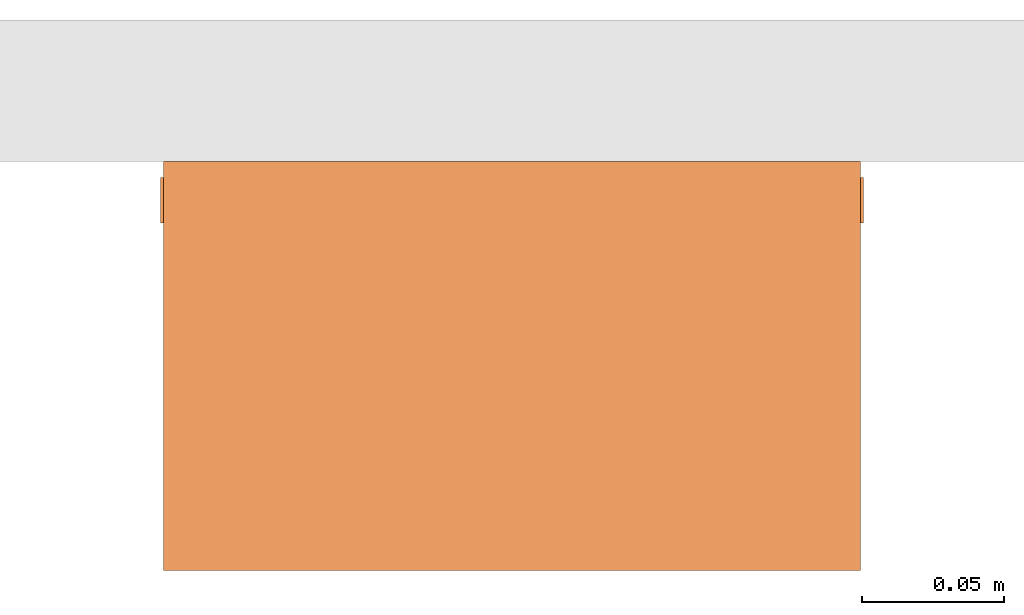
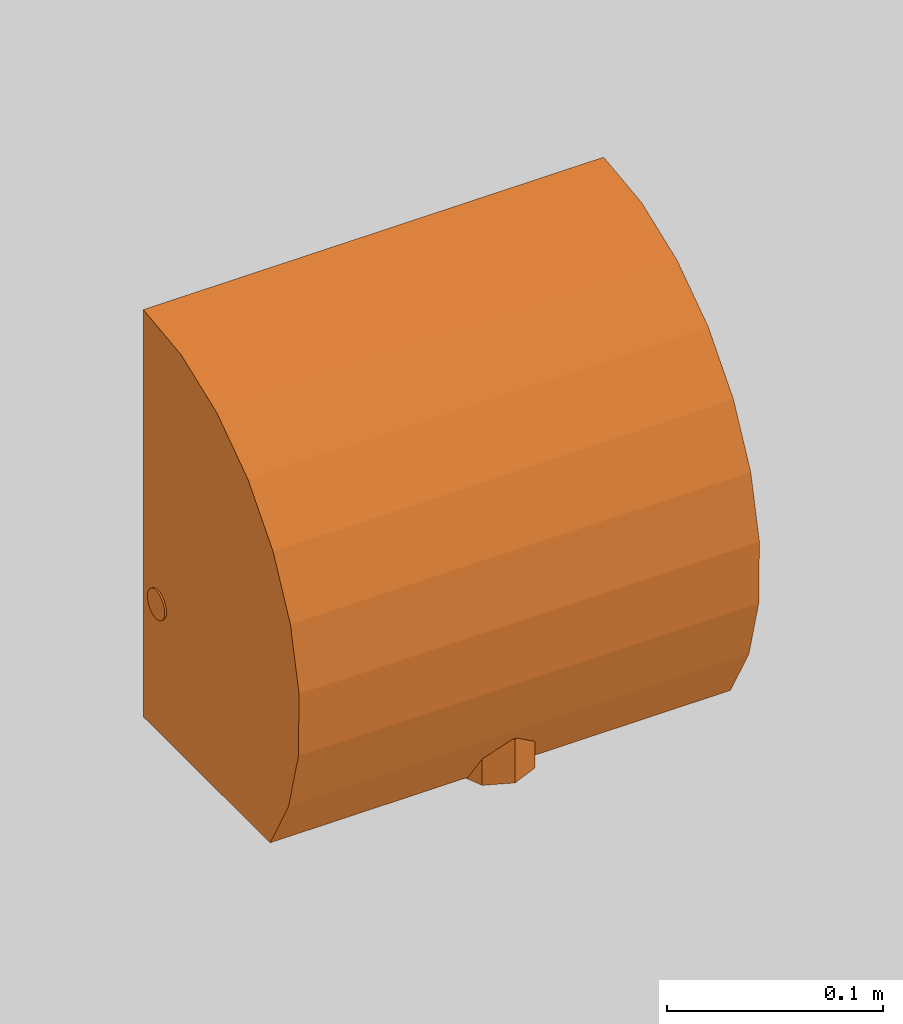
# One storey, part 2 of 2: 1 proxy.
"""IFC2X3 building model written with IfcOpenShell, lengths in millimetres."""

from ifc_helpers import new_model, entity, si_unit, converted_unit, derived_unit, direction, frame, origin, place, context, subcontext, project, spatial, faceted_brep, source, transform, mapped, material, material_list, element, save


model = new_model("IFC2X3")

# Units and contexts
model_context = context("Model", 3, precision=1e-05, world=origin(), true_north=direction((2.0, 6.12303176911189e-17, 1.0)))
context_of_model = context(None, 3, precision=1e-05, world=origin(), true_north=direction((2.0, 6.12303176911189e-17, 1.0)))
body_context = subcontext(model_context, "Body", "Model", "MODEL_VIEW")
ifc_project = project(units=[si_unit("LENGTHUNIT", "METRE", prefix="MILLI"), si_unit("AREAUNIT", "SQUARE_METRE"), si_unit("VOLUMEUNIT", "CUBIC_METRE"), converted_unit("PLANEANGLEUNIT", "DEGREE", entity("IfcRatioMeasure", 0.0174532925199433), si_unit("PLANEANGLEUNIT", "RADIAN"), dimensions=[0, 0, 0, 0, 0, 0, 0]), si_unit("MASSUNIT", "GRAM", prefix="KILO"), si_unit("TIMEUNIT", "SECOND"), si_unit("THERMODYNAMICTEMPERATUREUNIT", "KELVIN"), derived_unit("THERMALTRANSMITTANCEUNIT", [(si_unit("MASSUNIT", "GRAM", prefix="KILO"), 1), (si_unit("THERMODYNAMICTEMPERATUREUNIT", "KELVIN"), -1), (si_unit("TIMEUNIT", "SECOND"), -3)]), derived_unit("VOLUMETRICFLOWRATEUNIT", [(si_unit("LENGTHUNIT", "METRE"), 3), (si_unit("TIMEUNIT", "SECOND"), -1)]), si_unit("POWERUNIT", "WATT")], contexts=[model_context, context_of_model])

# Site, building, storey
site_placement = place(None, origin())
site = spatial("IfcSite", under=ifc_project, at=site_placement, CompositionType="ELEMENT")
building_placement = place(site_placement, origin())
building = spatial("IfcBuilding", under=site, at=building_placement, CompositionType="ELEMENT")
storey_placement = place(building_placement, origin())
storey = spatial("IfcBuildingStorey", under=building, at=storey_placement, Name="Level 1", CompositionType="ELEMENT", Elevation=0.0)

# Proxy
ifc_material_1 = material()
ifc_material_2 = material(Name="Stainless Steel")
ifc_material_list = material_list([ifc_material_1, ifc_material_2])
shared_shape = source(origin(), body_context, "Body", "Brep", [
    faceted_brep([(124.0, -11.5005440967139, 64.2506713870273), (124.0, -9.57109645753406, 65.0498747670644), (124.0, -7.91424220804167, 66.3212237478475), (124.0, -6.64289322725854, 67.9780779973399), (124.0, -5.8436898472215, 69.9075256365197), (124.0, -5.57109645753403, 71.9780779973399), (124.0, -5.84368984722149, 74.0486303581601), (124.0, -6.64289322725853, 75.9780779973399), (124.0, -7.91424220804166, 77.6349322468323), (124.0, -9.57109645753404, 78.9062812276154), (124.0, -11.5005440967139, 79.7054846076524), (124.0, -13.571096457534, 79.9780779973399), (124.0, -15.6416488183542, 79.7054846076524), (124.0, -17.571096457534, 78.9062812276154), (124.0, -19.2279507070264, 77.6349322468323), (124.0, -20.4992996878095, 75.9780779973399), (124.0, -21.2985030678466, 74.0486303581601), (124.0, -21.571096457534, 71.9780779973399), (124.0, -21.2985030678466, 69.9075256365197), (124.0, -20.4992996878096, 67.9780779973399), (124.0, -19.2279507070264, 66.3212237478475), (124.0, -17.5710964575341, 65.0498747670644), (124.0, -15.6416488183542, 64.2506713870273), (124.0, -13.5710964575341, 63.9780779973399), (-124.0, -15.6416488183542, 79.7054846076524), (-124.0, -13.571096457534, 79.9780779973399), (-124.0, -11.5005440967139, 79.7054846076524), (-124.0, -9.57109645753405, 78.9062812276154), (-124.0, -7.91424220804167, 77.6349322468323), (-124.0, -6.64289322725854, 75.9780779973399), (-124.0, -5.8436898472215, 74.0486303581601), (-124.0, -5.57109645753404, 71.9780779973399), (-124.0, -5.84368984722151, 69.9075256365197), (-124.0, -6.64289322725855, 67.9780779973399), (-124.0, -7.91424220804169, 66.3212237478475), (-124.0, -9.57109645753407, 65.0498747670644), (-124.0, -11.5005440967139, 64.2506713870273), (-124.0, -13.5710964575341, 63.9780779973399), (-124.0, -15.6416488183542, 64.2506713870273), (-124.0, -17.5710964575341, 65.0498747670644), (-124.0, -19.2279507070264, 66.3212237478475), (-124.0, -20.4992996878096, 67.9780779973399), (-124.0, -21.2985030678466, 69.9075256365197), (-124.0, -21.571096457534, 71.9780779973399), (-124.0, -21.2985030678466, 74.0486303581601), (-124.0, -20.4992996878096, 75.9780779973399), (-124.0, -19.2279507070264, 77.6349322468323), (-124.0, -17.571096457534, 78.9062812276154), (-25.2396801832763, -21.571096457534, 71.9780779973399), (27.1675165426169, -14.6456161051512, 64.0505684560725), (25.2396823256753, -21.571096457534, 71.9780779973399), (25.2396820893137, -5.57109645753404, 71.9780779973398), (34.1434144249156, -13.571096496483, 79.9780779973399)], [[[0, 1, 2, 3, 4, 5, 6, 7, 8, 9, 10, 11, 12, 13, 14, 15, 16, 17, 18, 19, 20, 21, 22, 23]], [[24, 25, 26, 27, 28, 29, 30, 31, 32, 33, 34, 35, 36, 37, 38, 39, 40, 41, 42, 43, 44, 45, 46, 47]], [[48, 42, 41]], [[40, 39, 48]], [[48, 38, 49]], [[21, 20, 49]], [[48, 43, 42]], [[18, 17, 50, 48]], [[38, 48, 39]], [[31, 51, 32]], [[5, 4, 51]], [[18, 49, 19]], [[49, 20, 19]], [[51, 4, 3]], [[48, 41, 40]], [[35, 34, 49]], [[48, 49, 18]], [[38, 37, 49]], [[49, 34, 51]], [[21, 49, 22]], [[49, 0, 23]], [[32, 51, 33]], [[51, 34, 33]], [[49, 36, 35]], [[51, 2, 49]], [[0, 49, 1]], [[51, 3, 2]], [[1, 49, 2]], [[23, 22, 49]], [[36, 49, 37]], [[51, 29, 28]], [[28, 27, 52]], [[50, 14, 52]], [[31, 30, 51]], [[6, 5, 51]], [[27, 26, 52]], [[47, 52, 24]], [[30, 29, 51]], [[8, 52, 9]], [[8, 51, 52]], [[51, 8, 7]], [[51, 7, 6]], [[46, 52, 47]], [[44, 43, 48, 50]], [[17, 16, 50]], [[50, 52, 46]], [[50, 46, 45]], [[11, 52, 12]], [[24, 52, 25]], [[50, 16, 15]], [[44, 50, 45]], [[10, 9, 52]], [[12, 52, 13]], [[28, 52, 51]], [[13, 52, 14]], [[52, 11, 10]], [[52, 26, 25]], [[50, 15, 14]]]),
    faceted_brep([(0.0, -111.00200803427, 23.6011645526978), (0.0, -91.0020080342704, 23.6011645526978), (-4.98699927364723, -93.0676907689599, 23.6011645526978), (-7.07106781186553, -93.930940222405, 23.6011645526978), (-10.6066017177983, -95.3954063164722, 23.6011645526978), (-14.142135623731, -96.8598724105395, 23.6011645526978), (-15.6066017177982, -100.395406316472, 23.6011645526978), (-17.0710678118655, -103.930940222405, 23.6011645526978), (-18.5355339059327, -107.466474128338, 23.6011645526978), (-20.0, -111.00200803427, 23.6011645526978), (-18.5355339059327, -114.537541940203, 23.6011645526978), (-17.0710678118655, -118.073075846136, 23.6011645526978), (-15.6066017177982, -121.608609752069, 23.6011645526978), (-14.1421356237309, -125.144143658001, 23.6011645526978), (-9.97399850047373, -126.870642584285, 23.6011645526978), (-4.98699925023687, -128.936325309278, 23.6011645526978), (0.0, -131.00200803427, 23.6011645526978), (4.98699939050512, -128.936325251177, 23.6011645526978), (4.98699924271073, -93.0676907561456, 23.6011645526978), (9.97399848542152, -95.1333734780207, 23.6011645526978), (14.1421356237309, -96.8598724105394, 23.6011645526978), (15.6066017177982, -100.395406316472, 23.6011645526978), (17.0710678118654, -103.930940222405, 23.6011645526978), (18.5355339059327, -107.466474128338, 23.6011645526978), (20.0, -111.00200803427, 23.6011645526978), (7.07106781186557, -128.073075846136, 23.6011645526978), (10.6066017177983, -126.608609752069, 23.6011645526978), (14.142135623731, -125.144143658001, 23.6011645526978), (15.6066017177983, -121.608609752069, 23.6011645526978), (17.0710678118655, -118.073075846136, 23.6011645526978), (18.5355339059328, -114.537541940203, 23.6011645526978), (-14.1421356237309, -125.144143658001, -1.0), (-10.6066017177982, -126.608609752069, -1.0), (-7.07106781186547, -128.073075846136, -1.0), (-4.98699923859718, -128.936325314099, -1.0), (0.0, -131.00200803427, -1.0), (-20.0, -111.00200803427, -1.0), (-18.5355339059327, -114.537541940203, -1.0), (-17.0710678118655, -118.073075846136, -1.0), (-15.6066017177982, -121.608609752069, -1.0), (-7.07106781186553, -93.930940222405, -1.0), (-10.6066017177983, -95.3954063164722, -1.0), (-14.142135623731, -96.8598724105395, -1.0), (0.0, -91.0020080342704, -1.0), (-3.5355339059328, -92.4664741283377, -1.0), (-17.0710678118655, -103.930940222405, -1.0), (-18.5355339059327, -107.466474128338, -1.0), (-15.6066017177982, -100.395406316472, -1.0), (14.1421356237309, -96.8598724105394, -1.0), (10.6066017177982, -95.3954063164722, -1.0), (7.07106781186542, -93.9309402224049, -1.0), (4.98699923698029, -93.0676907537719, -1.0), (20.0, -111.00200803427, -1.0), (18.5355339059327, -107.466474128338, -1.0), (17.0710678118655, -103.930940222405, -1.0), (15.6066017177982, -100.395406316472, -1.0), (7.07106781186558, -128.073075846136, -1.0), (10.6066017177983, -126.608609752069, -1.0), (14.142135623731, -125.144143658001, -1.0), (3.53553390593286, -129.537541940203, -1.0), (15.6066017177983, -121.608609752069, -1.0), (17.0710678118655, -118.073075846136, -1.0), (18.5355339059328, -114.537541940203, -1.0), (0.0, -111.00200803427, -1.0)], [[[0, 1, 2]], [[0, 2, 3]], [[0, 3, 4]], [[0, 4, 5]], [[0, 5, 6]], [[0, 6, 7]], [[0, 7, 8]], [[0, 8, 9]], [[0, 9, 10]], [[0, 10, 11]], [[0, 11, 12]], [[0, 12, 13]], [[0, 13, 14]], [[0, 14, 15]], [[0, 15, 16]], [[0, 16, 17]], [[0, 18, 1]], [[0, 19, 18]], [[0, 20, 19]], [[0, 21, 20]], [[0, 22, 21]], [[0, 23, 22]], [[0, 24, 23]], [[0, 17, 25]], [[0, 25, 26]], [[0, 26, 27]], [[0, 27, 28]], [[0, 28, 29]], [[0, 29, 30]], [[0, 30, 24]], [[15, 14, 13, 31, 32, 33, 34, 35, 16]], [[9, 36, 37, 38, 39, 31, 13, 12, 11, 10]], [[40, 41, 42, 5, 4, 3, 2, 1, 43, 44]], [[45, 46, 36, 9, 8, 7, 6, 5, 42, 47]], [[18, 19, 20, 48, 49, 50, 51, 43, 1]], [[24, 52, 53, 54, 55, 48, 20, 21, 22, 23]], [[56, 57, 58, 27, 26, 25, 17, 16, 35, 59]], [[60, 61, 62, 52, 24, 30, 29, 28, 27, 58]], [[63, 42, 41]], [[63, 41, 40]], [[63, 40, 44]], [[63, 44, 43]], [[63, 43, 51]], [[63, 47, 42]], [[63, 45, 47]], [[63, 46, 45]], [[63, 36, 46]], [[63, 37, 36]], [[63, 38, 37]], [[63, 39, 38]], [[63, 31, 39]], [[63, 32, 31]], [[63, 33, 32]], [[63, 34, 33]], [[63, 35, 34]], [[63, 51, 50]], [[63, 50, 49]], [[63, 49, 48]], [[63, 48, 55]], [[63, 55, 54]], [[63, 54, 53]], [[63, 53, 52]], [[63, 52, 62]], [[63, 59, 35]], [[63, 56, 59]], [[63, 57, 56]], [[63, 58, 57]], [[63, 62, 61]], [[63, 61, 60]], [[63, 60, 58]]]),
    faceted_brep([(123.0, -117.457138817092, 0.0), (123.0, 0.0162624276155045, 0.0), (123.0, 0.0162624276155367, 230.0), (123.0, -35.0319347903899, 225.700475733981), (123.0, -68.0016413267522, 213.056880989903), (123.0, -96.9376288601374, 192.819028766554), (123.0, -120.123883865565, 166.187100260162), (123.0, -136.185373708083, 134.740469579197), (123.0, -144.169591279742, 100.344040885004), (123.0, -143.603042274409, 65.0376525201357), (123.0, -134.519325191346, 30.9151068779775), (-123.0, -68.0016413267522, 213.056880989903), (-123.0, -35.0319347903899, 225.700475733981), (-123.0, 0.016262427614588, 230.0), (-123.0, 0.0162624276154998, 0.0), (-123.0, -117.457138817093, 0.0), (-123.0, -134.519325191346, 30.9151068779775), (-123.0, -143.603042274409, 65.0376525201357), (-123.0, -144.169591279742, 100.344040885004), (-123.0, -136.185373708083, 134.740469579197), (-123.0, -120.123883865565, 166.187100260162), (-123.0, -96.9376288601374, 192.819028766554)], [[[0, 1, 2, 3, 4, 5, 6, 7, 8, 9, 10]], [[11, 12, 13, 14, 15, 16, 17, 18, 19, 20, 21]], [[2, 1, 14, 13]], [[2, 13, 12, 3]], [[4, 11, 21, 5]], [[12, 11, 4, 3]], [[5, 21, 20, 6]], [[20, 19, 7, 6]], [[7, 19, 18, 8]], [[9, 17, 16, 10]], [[18, 17, 9, 8]], [[10, 16, 15, 0]], [[1, 0, 15, 14]]]),
])
proxy_placement = place(storey_placement, frame((1298.20150339073, 3952.69853342699, 357.139423611487)))
element("IfcBuildingElementProxy", 1, at=proxy_placement, inside=storey, material=ifc_material_list, Name="BC2002:BC2002 Eco Hand Dryer", ObjectType="BC2002 Eco Hand Dryer", CompositionType="ELEMENT", context=body_context, shape_type="MappedRepresentation", body=[
    mapped(shared_shape, transform((0.0, 0.0, 0.0), scale=1.0)),
])

save(model, "model.ifc")
